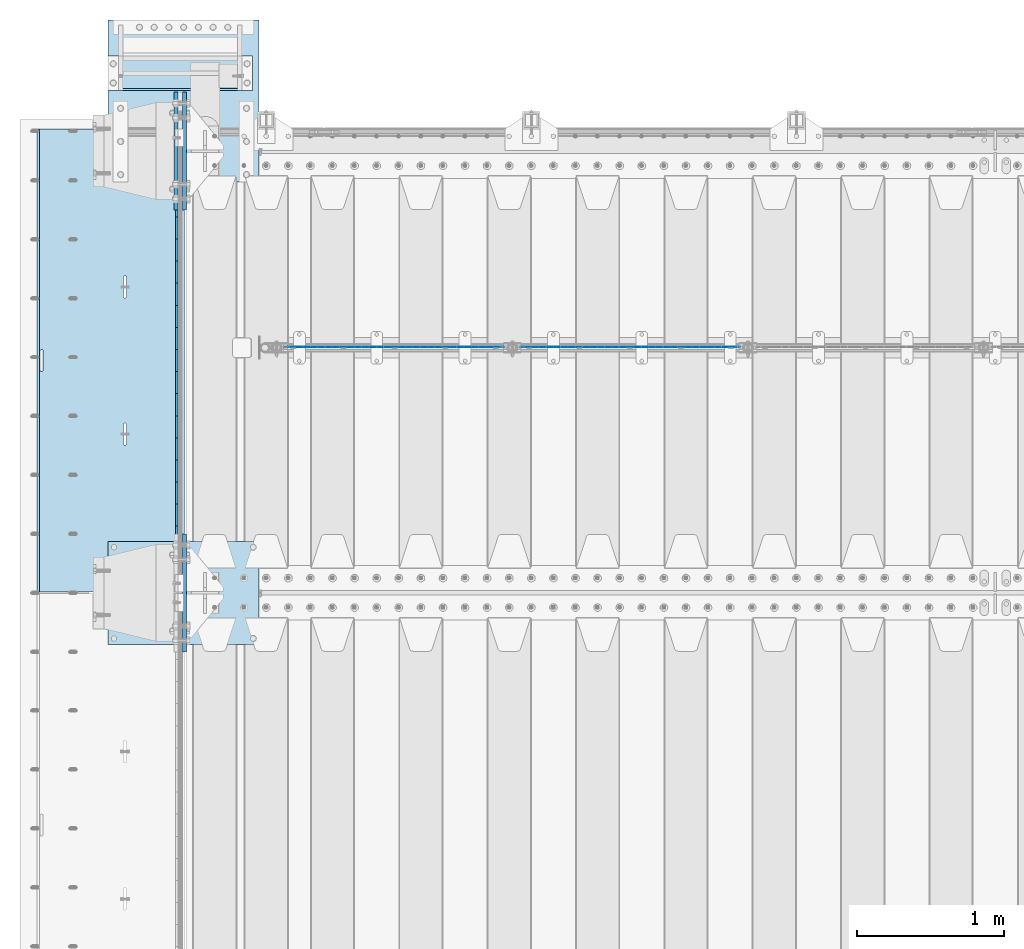
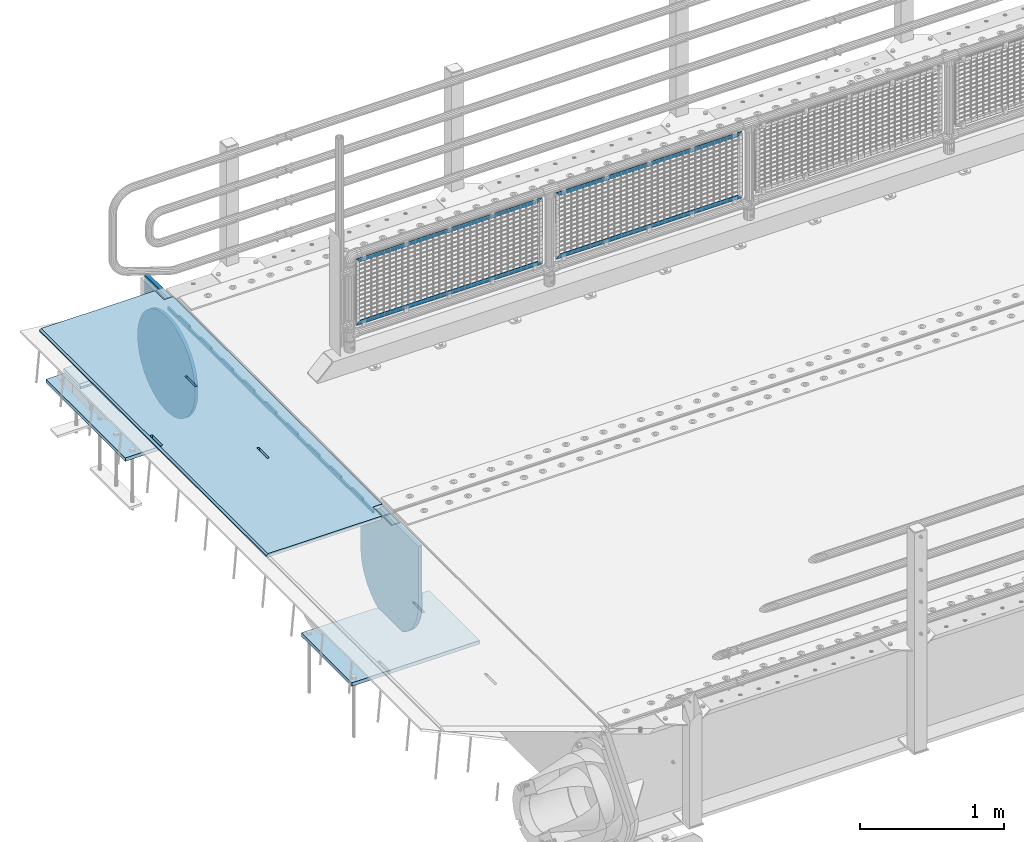
# One storey, part 163 of 208: 12 plates.
"""IFC2X3 building model written with IfcOpenShell, lengths in millimetres."""

import ifcopenshell
import ifcopenshell.guid

model = None  # the IFC model being written
_history = None  # IfcOwnerHistory: only IFC2X3 demands one
_inside = {}  # id of a spatial element -> (the spatial element, [elements in it])
_under = {}  # id of a project, library or spatial element -> (it, [spatial elements below it])
_declared = {}  # id of a project -> (the project, [libraries it declares])
_typed = {}  # id of a type object -> (the type object, [elements of that type])
_made_of = {}  # id of a material, layer set ... -> (it, [elements and type objects made of it])


def new_model(schema):
    """Start an empty IFC model of exactly this schema.

    Asked for "IFC4X3", IfcOpenShell would pick the latest addendum, in which some entities
    have other attributes; the version numbers below select the first issue.
    IFC2X3 requires an IfcOwnerHistory on every rooted entity: one is made here for all.
    """
    global model, _history
    if schema == "IFC4X3":
        model = ifcopenshell.file(schema_version=(4, 3, 0, 0))
    else:
        model = ifcopenshell.file(schema=schema)
    _inside.clear()
    _under.clear()
    _declared.clear()
    _typed.clear()
    _made_of.clear()
    _history = None
    if model.schema == "IFC2X3":
        org = make("IfcOrganization", Name="unknown")
        user = make(
            "IfcPersonAndOrganization",
            ThePerson=make("IfcPerson", FamilyName="unknown"),
            TheOrganization=org,
        )
        app = make(
            "IfcApplication",
            ApplicationDeveloper=org,
            Version="unknown",
            ApplicationFullName="unknown",
            ApplicationIdentifier="unknown",
        )
        _history = make(
            "IfcOwnerHistory",
            OwningUser=user,
            OwningApplication=app,
            ChangeAction="ADDED",
            CreationDate=0,
        )
    return model


def make(cls, **values):
    """One entity of the class cls with the attributes given. An attribute that is None is left unset."""
    return model.create_entity(
        cls, **{name: value for name, value in values.items() if value is not None}
    )


def rooted(cls, **values):
    """An entity with a GlobalId (a new one), such as an element, a storey or a relation."""
    return make(cls, GlobalId=ifcopenshell.guid.new(), OwnerHistory=_history, **values)


def si_unit(unit_type, name, prefix=None):
    """IfcSIUnit, for example si_unit("LENGTHUNIT", "METRE", prefix="MILLI")."""
    return make("IfcSIUnit", UnitType=unit_type, Prefix=prefix, Name=name)


def assignment(units):
    """IfcUnitAssignment: the units of a project."""
    return None if units is None else make("IfcUnitAssignment", Units=units)


def point(xyz):
    """IfcCartesianPoint."""
    return None if xyz is None else make("IfcCartesianPoint", Coordinates=xyz)


def direction(xyz):
    """IfcDirection."""
    return None if xyz is None else make("IfcDirection", DirectionRatios=xyz)


def frame(location, z_axis=None, x_axis=None):
    """IfcAxis2Placement3D, a coordinate frame: its origin and axes. An axis left out is left unset."""
    return make(
        "IfcAxis2Placement3D",
        Location=point(location),
        Axis=direction(z_axis),
        RefDirection=direction(x_axis),
    )


def origin_with_axes():
    """The frame at (0, 0, 0) with the z axis (0, 0, 1) and the x axis (1, 0, 0) written out."""
    return frame((0.0, 0.0, 0.0), z_axis=(0.0, 0.0, 1.0), x_axis=(1.0, 0.0, 0.0))


def place(relative_to, where):
    """IfcLocalPlacement: puts the frame where relative to a parent placement (None: the world)."""
    return make(
        "IfcLocalPlacement", PlacementRelTo=relative_to, RelativePlacement=where
    )


def context(
    kind, dimensions, precision=None, world=None, true_north=None, identifier=None
):
    """IfcGeometricRepresentationContext, for example the 3D "Model" context."""
    return make(
        "IfcGeometricRepresentationContext",
        ContextIdentifier=identifier,
        ContextType=kind,
        CoordinateSpaceDimension=dimensions,
        Precision=precision,
        WorldCoordinateSystem=world,
        TrueNorth=true_north,
    )


def subcontext(parent, identifier, kind, view, scale=None):
    """IfcGeometricRepresentationSubContext, for example "Body" below "Model"."""
    return make(
        "IfcGeometricRepresentationSubContext",
        ContextIdentifier=identifier,
        ContextType=kind,
        ParentContext=parent,
        TargetScale=scale,
        TargetView=view,
    )


def project(units=None, contexts=None):
    """IfcProject with its units and contexts."""
    return rooted(
        "IfcProject",
        Name="project",
        RepresentationContexts=contexts,
        UnitsInContext=assignment(units),
    )


def spatial(cls, under=None, at=None, **own):
    """A site, building, storey or space (cls), placed at a placement, below another one or the project."""
    s = rooted(cls, ObjectPlacement=at, **own)
    if under is not None:
        _under.setdefault(under.id(), (under, []))[1].append(s)
    return s


def faces_of(points, faces, orient=None, outer=None):
    """IfcFace entities. A face is a list of loops; a loop is a list of indices into points, from 0.

    orient and outer hold one flag for each loop. By default every Orientation is true, the
    first loop of a face is its IfcFaceOuterBound and the others are IfcFaceBound.
    """
    made = []
    for i, loops in enumerate(faces):
        bounds = []
        for j, loop in enumerate(loops):
            is_outer = j == 0 if outer is None else outer[i][j]
            bounds.append(
                make(
                    "IfcFaceOuterBound" if is_outer else "IfcFaceBound",
                    Bound=make("IfcPolyLoop", Polygon=[points[k] for k in loop]),
                    Orientation=True if orient is None else orient[i][j],
                )
            )
        made.append(make("IfcFace", Bounds=bounds))
    return made


def faceted_brep(points, faces, orient=None, outer=None, voids=None):
    """IfcFacetedBrep: a solid bounded by flat faces; with voids (closed shells), ...WithVoids."""
    shared = [point(p) for p in points]
    hull = make("IfcClosedShell", CfsFaces=faces_of(shared, faces, orient, outer))
    if voids is None:
        return make("IfcFacetedBrep", Outer=hull)
    return make(
        "IfcFacetedBrepWithVoids",
        Outer=hull,
        Voids=[
            make(cls, CfsFaces=faces_of(shared, fs, o, b)) for cls, fs, o, b in voids
        ],
    )


def shape(context_of_items, identifier, shape_type, items):
    """IfcShapeRepresentation: the items that make up one representation, for example the "Body"."""
    return make(
        "IfcShapeRepresentation",
        ContextOfItems=context_of_items,
        RepresentationIdentifier=identifier,
        RepresentationType=shape_type,
        Items=items,
    )


def material(Name=None, Category=None):
    """IfcMaterial."""
    return make("IfcMaterial", Name=Name, Category=Category)


def made_of(thing, what):
    """Note that an element or type object is made of a material, layer set ...; save() writes the relation."""
    if what is not None:
        _made_of.setdefault(what.id(), (what, []))[1].append(thing)
    return thing


def type_object(cls, material=None, **own):
    """A type object (cls), such as IfcWallType, which elements share."""
    return made_of(rooted(cls, **own), material)


def element(
    cls,
    number,
    at=None,
    inside=None,
    cuts=None,
    type_object=None,
    material=None,
    context=None,
    identifier="Body",
    shape_type=None,
    held_by="IfcProductDefinitionShape",
    body=None,
    shapes=None,
    **own,
):
    """One element of the class cls, such as IfcWall. Its Tag is "e" and its number.

    at: its placement. inside: the storey or other place that contains it. cuts: it is an
    opening in that element (IfcRelVoidsElement). A single representation is given by context,
    identifier, shape_type and body (its items); several are given by shapes. held_by: the class
    of the entity that holds the representations. save() writes the other relations.
    """
    e = rooted(cls, Tag="e%d" % number, ObjectPlacement=at, **own)
    if body is not None:
        shapes = [shape(context, identifier, shape_type, body)]
    if shapes is not None:
        e.Representation = make(held_by, Representations=shapes)
    if inside is not None:
        _inside.setdefault(inside.id(), (inside, []))[1].append(e)
    if cuts is not None:
        rooted(
            "IfcRelVoidsElement", RelatingBuildingElement=cuts, RelatedOpeningElement=e
        )
    if type_object is not None:
        _typed.setdefault(type_object.id(), (type_object, []))[1].append(e)
    return made_of(e, material)


def aggregate(whole, parts):
    """IfcRelAggregates: a whole, such as a stair, and the parts it consists of."""
    return rooted("IfcRelAggregates", RelatingObject=whole, RelatedObjects=parts)


def save(model, path):
    """Write the relations noted so far, then the file.

    IfcRelAggregates (storeys below a building ...), IfcRelContainedInSpatialStructure (elements
    in a storey), IfcRelDefinesByType, IfcRelAssociatesMaterial and IfcRelDeclares: one each for
    every whole, place, type object, material and project.
    """
    for whole, parts in _under.values():
        aggregate(whole, parts)
    for where, things in _inside.values():
        rooted(
            "IfcRelContainedInSpatialStructure",
            RelatedElements=things,
            RelatingStructure=where,
        )
    for kind, things in _typed.values():
        rooted("IfcRelDefinesByType", RelatedObjects=things, RelatingType=kind)
    for what, things in _made_of.values():
        rooted("IfcRelAssociatesMaterial", RelatedObjects=things, RelatingMaterial=what)
    for by, libraries in _declared.values():
        rooted("IfcRelDeclares", RelatingContext=by, RelatedDefinitions=libraries)
    model.write(path)


model = new_model("IFC2X3")

# Units and contexts
model_context = context("Model", 3, precision=1e-05, world=origin_with_axes())
body_context = subcontext(model_context, "Body", "Model", "MODEL_VIEW")
ifc_project = project(units=[si_unit("LENGTHUNIT", "METRE", prefix="MILLI"), si_unit("AREAUNIT", "SQUARE_METRE"), si_unit("VOLUMEUNIT", "CUBIC_METRE"), si_unit("MASSUNIT", "GRAM", prefix="KILO"), si_unit("TIMEUNIT", "SECOND"), si_unit("PLANEANGLEUNIT", "RADIAN"), si_unit("SOLIDANGLEUNIT", "STERADIAN"), si_unit("THERMODYNAMICTEMPERATUREUNIT", "DEGREE_CELSIUS"), si_unit("LUMINOUSINTENSITYUNIT", "LUMEN")], contexts=[model_context])

# Site, building, storey
site_placement = place(None, origin_with_axes())
site = spatial("IfcSite", under=ifc_project, at=site_placement, CompositionType="ELEMENT")
building_placement = place(site_placement, origin_with_axes())
building = spatial("IfcBuilding", under=site, at=building_placement, Name="Standard", CompositionType="ELEMENT")
storey_placement = place(building_placement, origin_with_axes())
storey = spatial("IfcBuildingStorey", under=building, at=storey_placement, Name="Undefined", CompositionType="ELEMENT", Elevation=0.0)

# Plates
ifc_material_1 = material(Name="STEEL/S355N")
plate_type_1 = type_object("IfcPlateType", PredefinedType="NOTDEFINED")
plate_1_placement = place(storey_placement, frame((-42455.0037545708, 6149.99992612935, -0.984391683580506), z_axis=(1.0000003385235e-09, -0.999999999987744, -4.95099999993936e-06), x_axis=(-0.999999999879068, -1.00000022173607e-09, -1.55519999981193e-05)))
element("IfcPlate", 1, at=plate_1_placement, inside=storey, type_object=plate_type_1, material=ifc_material_1, context=body_context, shape_type="Brep", body=[
    faceted_brep([(14.9998601691623, 15.0, 125.000024820844), (-0.000294611330900807, -0.000806902962786349, 124.999936248646), (-0.00191941577941179, 0.000806844426833264, 3020.00000492305), (14.9966216875036, 15.0, 3020.00007976653), (999.996459960938, 5.0, 1.81898940354586e-12), (984.996459960938, 15.0, 1.36424205265939e-12), (984.996459718779, 15.0, 3145.0), (999.996459718779, 5.0, 3145.0), (984.996459961352, -15.0, 1.81898940354586e-12), (999.996459960938, -4.99999999999848, 1.36424205265939e-12), (999.996459718779, -4.99999999999848, 3145.0), (984.996459719194, -15.0, 3145.0), (394.996621833969, -14.9999999992854, 1137.49999999815), (394.996621833976, 15.0, 1137.49999999815), (395.486056670787, 15.0, 1140.5901699419), (395.486056670779, -14.9999999992867, 1140.5901699419), (396.906451889772, 15.0, 1143.37785252108), (396.906451889765, -14.9999999992902, 1143.37785252108), (399.118769310422, 15.0, 1145.5901699419), (399.118769310422, -14.9999999992955, 1145.5901699419), (401.906451889488, 15.0, 1147.0105651611), (401.906451889496, -14.999999999302, 1147.0105651611), (404.996621833197, 15.0, 1147.49999999815), (404.996621833197, -14.9999999993092, 1147.49999999815), (408.086791776987, 15.0, 1147.0105651611), (408.086791776987, -14.9999999993163, 1147.0105651611), (410.874474356264, 15.0, 1145.5901699419), (410.874474356264, -14.9999999993227, 1145.5901699419), (413.08679177727, 15.0, 1143.37785252107), (413.08679177727, -14.9999999993277, 1143.37785252107), (414.507186996678, 15.0, 1140.59016994189), (414.507186996678, -14.9999999993308, 1140.59016994189), (414.996621833961, 15.0, 1137.49999999814), (414.996621833961, -14.9999999993318, 1137.49999999814), (414.996621843871, 15.0, 1007.49999999814), (414.996621843871, -14.9999999993243, 1007.49999999814), (414.507187007061, 15.0, 1004.40983005439), (414.507187007061, -14.999999999323, 1004.4098300544), (413.086791788068, 15.0, 1001.62214747522), (413.086791788068, -14.9999999993196, 1001.62214747522), (410.874474367403, 15.0, 999.409830054399), (410.874474367411, -14.9999999993143, 999.409830054399), (408.086791788344, 15.0, 997.989434835199), (408.086791788344, -14.9999999993078, 997.989434835199), (404.996621844744, 15.0, 997.499999998151), (404.996621844752, -14.9999999993006, 997.499999998151), (401.906451900963, 15.0, 997.989434835199), (401.906451900963, -14.9999999992934, 997.989434835199), (399.118769321678, 15.0, 999.409830054401), (399.118769321678, -14.999999999287, 999.409830054401), (396.906451900686, 15.0, 1001.62214747523), (396.906451900679, -14.999999999282, 1001.62214747523), (395.486056681264, 15.0, 1004.4098300544), (395.486056681264, -14.9999999992789, 1004.4098300544), (394.99662184398, 15.0, 1007.49999999815), (394.996621843988, -14.999999999278, 1007.49999999815), (960.486056642767, -15.0000000006174, 1504.40983005415), (960.486056642767, 15.0, 1504.40983005415), (959.996621805483, 15.0, 1507.4999999979), (959.996621805491, -15.0000000006165, 1507.4999999979), (961.906451862189, -15.0000000006206, 1501.62214747498), (961.906451862189, 15.0, 1501.62214747498), (964.118769283188, -15.0000000006256, 1499.40983005415), (964.118769283188, 15.0, 1499.40983005415), (966.90645186248, -15.0000000006319, 1497.98943483495), (966.90645186248, 15.0, 1497.98943483495), (969.996621806255, -15.0000000006391, 1497.4999999979), (969.996621806247, 15.0, 1497.4999999979), (973.086791749854, -15.0000000006463, 1497.98943483495), (973.086791749854, 15.0, 1497.98943483495), (975.874474328928, -15.0000000006528, 1499.40983005415), (975.874474328921, 15.0, 1499.40983005415), (978.086791749571, -15.0000000006581, 1501.62214747497), (978.086791749571, 15.0, 1501.62214747497), (979.507186968556, -15.0000000006615, 1504.40983005415), (979.507186968556, 15.0, 1504.40983005415), (979.996621805367, -15.0000000006628, 1507.49999999789), (979.996621805367, 15.0, 1507.49999999789), (979.996621795464, -15.0000000006703, 1637.49999999789), (979.996621795464, 15.0, 1637.49999999789), (979.507186958181, -15.0000000006694, 1640.59016994164), (979.507186958181, 15.0, 1640.59016994164), (978.086791738773, -15.0000000006662, 1643.37785252082), (978.086791738773, 15.0, 1643.37785252082), (975.874474317781, -15.0000000006612, 1645.59016994165), (975.874474317781, 15.0, 1645.59016994165), (973.086791738489, -15.0000000006548, 1647.01056516085), (973.086791738489, 15.0, 1647.01056516085), (969.996621794693, -15.0000000006477, 1647.4999999979), (969.9966217947, 15.0, 1647.4999999979), (966.906451851006, -15.0000000006405, 1647.01056516085), (966.906451850999, 15.0, 1647.01056516085), (964.118769271932, -15.000000000634, 1645.59016994165), (964.118769271932, 15.0, 1645.59016994165), (961.906451851275, -15.0000000006287, 1643.37785252083), (961.906451851275, 15.0, 1643.37785252083), (960.486056632282, -15.0000000006253, 1640.59016994165), (960.486056632282, 15.0, 1640.59016994165), (959.996621795472, -15.000000000624, 1637.4999999979), (959.996621795472, 15.0, 1637.4999999979), (-0.000449375191237777, -14.9999999951863, 124.999861417758), (-0.00046036208368605, -15.00000004538, 3019.99993008592), (74.9964039658807, -14.999999998652, 3019.99993015413), (74.9968705258798, 15.0, 3020.00007982413), (74.9962640909944, -15.0, 3145.0), (74.9967306509934, 15.0, 3145.0), (74.9997820615899, -15.0, 0.0), (75.0002485915829, 15.0, -4.54747350886464e-13), (74.999642186689, -15.0, 124.999930084114), (75.0001087166966, 15.0, 125.000079754114), (395.486056593785, -15.0000000032097, 2140.59016994142), (396.906451812763, -15.0000000031847, 2143.3778525206), (399.118769233428, -15.0000000031445, 2145.59016994142), (401.906451812487, -15.0000000030931, 2147.01056516062), (404.996621756189, -15.0000000030354, 2147.49999999767), (408.086791699985, -15.0000000029771, 2147.01056516062), (410.874474279262, -15.000000002924, 2145.59016994142), (413.086791700269, -15.0000000028812, 2143.37785252059), (414.507186919684, -15.000000002853, 2140.59016994141), (414.996621756967, -15.000000002842, 2137.49999999766), (414.996621766863, -15.0000000027658, 2007.49999999766), (414.507186930052, -15.0000000027732, 2004.40983005391), (413.086791711066, -15.0000000027982, 2001.62214747474), (410.874474290409, -15.0000000028384, 1999.40983005392), (408.08679171135, -15.0000000028898, 1997.98943483472), (404.996621767757, -15.0000000029475, 1997.49999999767), (401.906451823961, -15.0000000030058, 1997.98943483472), (399.118769244684, -15.0000000030589, 1999.40983005392), (396.906451823685, -15.0000000031017, 2001.62214747475), (395.486056604263, -15.0000000031299, 2004.40983005392), (394.996621766979, -15.0000000031409, 2007.49999999767), (394.996621756974, -15.0000000032171, 2137.49999999767), (396.906451823692, 15.0, 2001.62214747475), (395.486056604263, 15.0, 2004.40983005392), (399.118769244684, 15.0, 1999.40983005392), (401.906451823961, 15.0, 1997.98943483472), (404.99662176775, 15.0, 1997.49999999767), (408.08679171135, 15.0, 1997.98943483472), (410.874474290409, 15.0, 1999.40983005392), (413.086791711074, 15.0, 2001.62214747474), (414.507186930052, 15.0, 2004.40983005391), (414.996621766863, 15.0, 2007.49999999766), (414.996621756967, 15.0, 2137.49999999766), (414.507186919676, 15.0, 2140.59016994141), (413.086791700269, 15.0, 2143.37785252059), (410.87447427927, 15.0, 2145.59016994142), (408.086791699985, 15.0, 2147.01056516062), (404.996621756189, 15.0, 2147.49999999767), (401.90645181248, 15.0, 2147.01056516062), (399.118769233428, 15.0, 2145.59016994142), (396.906451812771, 15.0, 2143.3778525206), (395.486056593785, 15.0, 2140.59016994142), (394.996621756974, 15.0, 2137.49999999767), (394.996621766972, 15.0, 2007.49999999767)], [[[0, 1, 2, 3]], [[4, 5, 6, 7]], [[8, 9, 10, 11]], [[12, 13, 14, 15]], [[15, 14, 16, 17]], [[17, 16, 18, 19]], [[19, 18, 20, 21]], [[21, 20, 22, 23]], [[23, 22, 24, 25]], [[25, 24, 26, 27]], [[27, 26, 28, 29]], [[29, 28, 30, 31]], [[31, 30, 32, 33]], [[33, 32, 34, 35]], [[35, 34, 36, 37]], [[37, 36, 38, 39]], [[39, 38, 40, 41]], [[41, 40, 42, 43]], [[43, 42, 44, 45]], [[45, 44, 46, 47]], [[47, 46, 48, 49]], [[49, 48, 50, 51]], [[51, 50, 52, 53]], [[53, 52, 54, 55]], [[55, 54, 13, 12]], [[56, 57, 58, 59]], [[60, 61, 57, 56]], [[62, 63, 61, 60]], [[64, 65, 63, 62]], [[66, 67, 65, 64]], [[68, 69, 67, 66]], [[70, 71, 69, 68]], [[72, 73, 71, 70]], [[74, 75, 73, 72]], [[76, 77, 75, 74]], [[78, 79, 77, 76]], [[80, 81, 79, 78]], [[82, 83, 81, 80]], [[84, 85, 83, 82]], [[86, 87, 85, 84]], [[88, 89, 87, 86]], [[90, 91, 89, 88]], [[92, 93, 91, 90]], [[94, 95, 93, 92]], [[96, 97, 95, 94]], [[98, 99, 97, 96]], [[59, 58, 99, 98]], [[100, 101, 2, 1]], [[101, 102, 103, 3, 2]], [[104, 105, 103, 102]], [[7, 6, 105, 104, 11, 10]], [[4, 7, 10, 9]], [[106, 107, 5, 4, 9, 8]], [[106, 108, 109, 107]], [[109, 108, 100, 1, 0]], [[104, 102, 101, 100, 108, 106, 8, 11], [15, 17, 19, 21, 23, 25, 27, 29, 31, 33, 35, 37, 39, 41, 43, 45, 47, 49, 51, 53, 55, 12], [96, 94, 92, 90, 88, 86, 84, 82, 80, 78, 76, 74, 72, 70, 68, 66, 64, 62, 60, 56, 59, 98], [110, 111, 112, 113, 114, 115, 116, 117, 118, 119, 120, 121, 122, 123, 124, 125, 126, 127, 128, 129, 130, 131]], [[128, 132, 133, 129]], [[127, 134, 132, 128]], [[126, 135, 134, 127]], [[125, 136, 135, 126]], [[124, 137, 136, 125]], [[123, 138, 137, 124]], [[122, 139, 138, 123]], [[121, 140, 139, 122]], [[120, 141, 140, 121]], [[119, 142, 141, 120]], [[118, 143, 142, 119]], [[117, 144, 143, 118]], [[116, 145, 144, 117]], [[115, 146, 145, 116]], [[114, 147, 146, 115]], [[113, 148, 147, 114]], [[112, 149, 148, 113]], [[111, 150, 149, 112]], [[110, 151, 150, 111]], [[131, 152, 151, 110]], [[130, 153, 152, 131]], [[129, 133, 153, 130]], [[107, 109, 0, 3, 103, 105, 6, 5], [50, 48, 46, 44, 42, 40, 38, 36, 34, 32, 30, 28, 26, 24, 22, 20, 18, 16, 14, 13, 54, 52], [132, 134, 135, 136, 137, 138, 139, 140, 141, 142, 143, 144, 145, 146, 147, 148, 149, 150, 151, 152, 153, 133], [61, 63, 65, 67, 69, 71, 73, 75, 77, 79, 81, 83, 85, 87, 89, 91, 93, 95, 97, 99, 58, 57]]]),
])
plate_type_2 = type_object("IfcPlateType", PredefinedType="NOTDEFINED")
plate_2_placement = place(storey_placement, frame((-42507.5, 6002.50009937252, -35.9858217417067), z_axis=(1.0000003385235e-09, -0.999999999987744, -4.95099999993936e-06), x_axis=(0.0, 4.95099999111973e-06, -0.999999999987744)))
element("IfcPlate", 2, at=plate_2_placement, inside=storey, type_object=plate_type_2, material=ifc_material_1, context=body_context, shape_type="Brep", body=[
    faceted_brep([(0.0, -7.5, -4.54747350886464e-13), (5.96145355302724e-12, -7.5, 150.0), (5.96145355302724e-12, 7.5, 150.0), (0.0, 7.5, -4.54747350886464e-13), (-15.0000000000013, -7.5, 150.0), (-15.0000000000013, 7.5, 150.0), (-15.0000000000026, -7.5, 300.0), (-15.0000000000026, 7.5, 300.0), (1.00826014204358e-11, -7.5, 300.0), (1.00826014204358e-11, 7.5, 300.0), (1.05870867628255e-11, -7.5, 450.0), (1.05870867628255e-11, 7.5, 450.0), (-15.000000000004, -7.5, 450.0), (-15.000000000004, 7.5, 450.0), (-15.0000000000053, -7.5, 600.0), (-15.0000000000053, 7.5, 600.0), (1.65343294611375e-11, -7.5, 600.0), (1.65343294611375e-11, 7.5, 600.0), (1.88506987797155e-11, -7.5, 750.0), (1.88506987797155e-11, 7.5, 750.0), (-15.0000000000066, -7.5, 750.0), (-15.0000000000066, 7.5, 750.0), (-15.0000000000079, -7.5, 900.0), (-15.0000000000079, 7.5, 900.0), (2.48050469053851e-11, -7.5, 900.0), (2.48050469053851e-11, 7.5, 900.0), (2.7121416223963e-11, -7.5, 1050.0), (2.7121416223963e-11, 7.5, 1050.0), (-15.0000000000093, -7.5, 1050.0), (-15.0000000000093, 7.5, 1050.0), (-15.0000000000106, -7.5, 1200.0), (-15.0000000000106, 7.5, 1200.0), (3.12638803734444e-11, -7.5, 1200.0), (3.12638803734444e-11, 7.5, 1200.0), (3.53921336682106e-11, -7.5, 1350.0), (3.53921336682106e-11, 7.5, 1350.0), (-15.0000000000119, -7.5, 1350.0), (-15.0000000000119, 7.5, 1350.0), (-15.0000000000132, -7.5, 1500.0), (-15.0000000000132, 7.5, 1500.0), (3.77085029867885e-11, -7.5, 1500.0), (3.77085029867885e-11, 7.5, 1500.0), (4.36628511124582e-11, -7.5, 1650.0), (4.36628511124582e-11, 7.5, 1650.0), (-15.0000000000145, -7.5, 1650.0), (-15.0000000000145, 7.5, 1650.0), (-15.0000000000159, -7.5, 1800.0), (-15.0000000000159, 7.5, 1800.0), (4.41531256001326e-11, -7.5, 1800.0), (4.41531256001326e-11, 7.5, 1800.0), (4.82884843222564e-11, -7.5, 1950.0), (4.82884843222564e-11, 7.5, 1950.0), (-15.0000000000172, -7.5, 1950.0), (-15.0000000000172, 7.5, 1950.0), (-15.0000000000185, -7.5, 2100.0), (-15.0000000000185, 7.5, 2100.0), (5.24309484717378e-11, -7.5, 2100.0), (5.24309484717378e-11, 7.5, 2100.0), (5.47402123629581e-11, -7.5, 2250.0), (5.47402123629581e-11, 7.5, 2250.0), (-15.0000000000198, -7.5, 2250.0), (-15.0000000000198, 7.5, 2250.0), (-15.0000000000212, -7.5, 2400.0), (-15.0000000000212, 7.5, 2400.0), (6.06945604886278e-11, -7.5, 2400.0), (6.06945604886278e-11, 7.5, 2400.0), (6.30038243798481e-11, -7.5, 2550.0), (6.30038243798481e-11, 7.5, 2550.0), (-15.0000000000225, -7.5, 2550.0), (-15.0000000000225, 7.5, 2550.0), (-15.0000000000238, -7.5, 2700.0), (-15.0000000000238, 7.5, 2700.0), (6.53272991257836e-11, -7.5, 2700.0), (6.53272991257836e-11, 7.5, 2700.0), (7.12745418240957e-11, -7.5, 2850.0), (7.12745418240957e-11, 7.5, 2850.0), (24.9999999999749, -7.5, 2850.0), (24.9999999999749, 7.5, 2850.0), (25.0, -7.5, -2.27373675443232e-12), (25.0, 7.5, -2.27373675443232e-12)], [[[0, 1, 2, 3]], [[1, 4, 5, 2]], [[4, 6, 7, 5]], [[6, 8, 9, 7]], [[8, 10, 11, 9]], [[10, 12, 13, 11]], [[12, 14, 15, 13]], [[14, 16, 17, 15]], [[16, 18, 19, 17]], [[18, 20, 21, 19]], [[20, 22, 23, 21]], [[22, 24, 25, 23]], [[24, 26, 27, 25]], [[26, 28, 29, 27]], [[28, 30, 31, 29]], [[30, 32, 33, 31]], [[32, 34, 35, 33]], [[34, 36, 37, 35]], [[36, 38, 39, 37]], [[38, 40, 41, 39]], [[40, 42, 43, 41]], [[42, 44, 45, 43]], [[44, 46, 47, 45]], [[46, 48, 49, 47]], [[48, 50, 51, 49]], [[50, 52, 53, 51]], [[52, 54, 55, 53]], [[54, 56, 57, 55]], [[56, 58, 59, 57]], [[58, 60, 61, 59]], [[60, 62, 63, 61]], [[62, 64, 65, 63]], [[64, 66, 67, 65]], [[66, 68, 69, 67]], [[68, 70, 71, 69]], [[70, 72, 73, 71]], [[72, 74, 75, 73]], [[74, 76, 77, 75]], [[76, 78, 79, 77]], [[78, 0, 3, 79]], [[5, 7, 9, 11, 13, 15, 17, 19, 21, 23, 25, 27, 29, 31, 33, 35, 37, 39, 41, 43, 45, 47, 49, 51, 53, 55, 57, 59, 61, 63, 65, 67, 69, 71, 73, 75, 77, 79, 3, 2]], [[78, 76, 74, 72, 70, 68, 66, 64, 62, 60, 58, 56, 54, 52, 50, 48, 46, 44, 42, 40, 38, 36, 34, 32, 30, 28, 26, 24, 22, 20, 18, 16, 14, 12, 10, 8, 6, 4, 1, 0]]]),
])
ifc_material_2 = material(Name="Misc_Undefined")
plate_type_3 = type_object("IfcPlateType", PredefinedType="NOTDEFINED")
plate_3_placement = place(storey_placement, frame((-40175.4949882696, 4670.5, 351.520303374641), z_axis=(0.0, 0.0, 1.0), x_axis=(1.0, 0.0, 0.0)))
element("IfcPlate", 3, at=plate_3_placement, inside=storey, type_object=plate_type_3, material=ifc_material_2, context=body_context, shape_type="Brep", body=[
    faceted_brep([(0.0, -1.49999999999909, 3.63797880709171e-12), (35.0002975463867, -1.5, 34.9996948242187), (35.0002975463867, 1.5, 34.9996948242187), (0.0, 1.50000000000182, 3.63797880709171e-12), (1457.99035644531, -1.5, 34.9999923706055), (1457.99035644531, 1.5, 34.9999923706055), (1492.98999023437, -1.5, -2.87985812974512e-09), (1492.98999023437, 1.5, -2.87985812974512e-09)], [[[0, 1, 2, 3]], [[1, 4, 5, 2]], [[4, 6, 7, 5]], [[6, 0, 3, 7]], [[5, 7, 3, 2]], [[6, 4, 1, 0]]]),
])
plate_4_placement = place(storey_placement, frame((-38682.4999998124, 4670.5, 914.520000175701), z_axis=(-0.707103624179499, 0.0, 0.707109938179501), x_axis=(-0.707109938179511, 0.0, -0.707103624179489)))
element("IfcPlate", 4, at=plate_4_placement, inside=storey, type_object=plate_type_3, material=ifc_material_2, context=body_context, shape_type="Brep", body=[
    faceted_brep([(0.0, -1.49999999999909, 3.63797880709171e-12), (1055.71520996092, -1.5, 1055.70581054688), (1055.71520996092, 1.5, 1055.70581054688), (0.0, 1.50000000000182, 3.63797880709171e-12), (1055.7081298828, -1.5, 1006.20135498047), (1055.7081298828, 1.5, 1006.20135498047), (49.4976959228516, -1.5, 6.91215973347425e-11), (49.4976959228516, 1.5, 6.91215973347425e-11)], [[[0, 1, 2, 3]], [[1, 4, 5, 2]], [[4, 6, 7, 5]], [[6, 0, 3, 7]], [[5, 7, 3, 2]], [[6, 4, 1, 0]]]),
])
plate_5_placement = place(storey_placement, frame((-41775.4949882696, 4670.5, 351.520303374641), z_axis=(0.0, 0.0, 1.0), x_axis=(1.0, 0.0, 0.0)))
element("IfcPlate", 5, at=plate_5_placement, inside=storey, type_object=plate_type_3, material=ifc_material_2, context=body_context, shape_type="Brep", body=[
    faceted_brep([(0.0, -1.49999999999909, 3.63797880709171e-12), (35.0002975463867, -1.5, 34.9996948242187), (35.0002975463867, 1.5, 34.9996948242187), (0.0, 1.50000000000182, 3.63797880709171e-12), (1457.99035644531, -1.5, 34.9999923706055), (1457.99035644531, 1.5, 34.9999923706055), (1492.98999023437, -1.5, -2.87985812974512e-09), (1492.98999023437, 1.5, -2.87985812974512e-09)], [[[0, 1, 2, 3]], [[1, 4, 5, 2]], [[4, 6, 7, 5]], [[6, 0, 3, 7]], [[5, 7, 3, 2]], [[6, 4, 1, 0]]]),
])
plate_6_placement = place(storey_placement, frame((-40282.4999998124, 4670.5, 914.520000175701), z_axis=(-0.707103624179499, 0.0, 0.707109938179501), x_axis=(-0.707109938179511, 0.0, -0.707103624179489)))
element("IfcPlate", 6, at=plate_6_placement, inside=storey, type_object=plate_type_3, material=ifc_material_2, context=body_context, shape_type="Brep", body=[
    faceted_brep([(0.0, -1.49999999999909, 3.63797880709171e-12), (1055.71520996092, -1.5, 1055.70581054688), (1055.71520996092, 1.5, 1055.70581054688), (0.0, 1.50000000000182, 3.63797880709171e-12), (1055.7081298828, -1.5, 1006.20135498047), (1055.7081298828, 1.5, 1006.20135498047), (49.4976959228516, -1.5, 6.91215973347425e-11), (49.4976959228516, 1.5, 6.91215973347425e-11)], [[[0, 1, 2, 3]], [[1, 4, 5, 2]], [[4, 6, 7, 5]], [[6, 0, 3, 7]], [[5, 7, 3, 2]], [[6, 4, 1, 0]]]),
])
plate_type_4 = type_object("IfcPlateType", PredefinedType="NOTDEFINED")
plate_7_placement = place(storey_placement, frame((-42455.0, 5600.0, -20.0), z_axis=(0.0, 1.0, 0.0), x_axis=(0.0, 0.0, -1.0)))
element("IfcPlate", 7, at=plate_7_placement, inside=storey, type_object=plate_type_4, material=ifc_material_1, context=body_context, shape_type="Brep", body=[
    faceted_brep([(855.0, -15.0, 572.963114671446), (855.0, 15.0, 572.963114671446), (849.182410261259, 15.0, 585.889268817516), (849.182410261259, -15.0, 585.889268817516), (824.193546357442, 15.0, 627.225898692465), (824.193546357442, -15.0, 627.225898692465), (794.404299268426, 15.0, 665.249063296316), (794.404299268426, -15.0, 665.249063296316), (760.249063296309, 15.0, 699.404299268435), (760.249063296309, -15.0, 699.404299268435), (722.22589869246, 15.0, 729.193546357455), (722.22589869246, -15.0, 729.193546357455), (680.889268817512, 15.0, 754.182410261274), (680.889268817512, -15.0, 754.182410261274), (636.841954817025, 15.0, 774.006497074155), (636.841954817025, -15.0, 774.006497074155), (590.726265715041, 15.0, 788.37672697041), (590.726265715041, -15.0, 788.37672697041), (543.214672102153, 15.0, 797.083549639213), (543.214672102153, -15.0, 797.083549639213), (495.0, -15.0, 800.000000000029), (495.0, 15.0, 800.0), (494.999999999412, -15.0, 0.0), (494.999999999412, 15.0, 0.0), (543.214672102129, 15.0, 2.91645036080718), (543.214672102129, -15.0, 2.91645036080718), (590.726265715023, 15.0, 11.6232730296078), (590.726265715023, -15.0, 11.6232730296078), (636.841954817014, 15.0, 25.9935029258631), (636.841954817014, -15.0, 25.9935029258631), (680.889268817507, 15.0, 45.8175897387455), (680.889268817507, -15.0, 45.8175897387455), (722.225898692462, 15.0, 70.8064536425663), (722.225898692462, -15.0, 70.8064536425663), (760.249063296318, 15.0, 100.595700731588), (760.249063296318, -15.0, 100.595700731588), (794.404299268441, 15.0, 134.750936703711), (794.404299268441, -15.0, 134.750936703711), (824.193546357463, 15.0, 172.774101307567), (824.193546357463, -15.0, 172.774101307567), (849.182410261284, 15.0, 214.110731182522), (849.182410261284, -15.0, 214.110731182522), (855.0, -15.0, 227.036885328535), (855.0, 15.0, 227.036885328535), (0.0, -15.0, 0.0), (0.0, 15.0, 0.0), (0.0, 15.0, 800.0), (0.0, -15.0, 800.0)], [[[0, 1, 2, 3]], [[3, 2, 4, 5]], [[5, 4, 6, 7]], [[7, 6, 8, 9]], [[9, 8, 10, 11]], [[11, 10, 12, 13]], [[13, 12, 14, 15]], [[15, 14, 16, 17]], [[17, 16, 18, 19]], [[20, 19, 18, 21]], [[22, 23, 24, 25]], [[25, 24, 26, 27]], [[27, 26, 28, 29]], [[29, 28, 30, 31]], [[31, 30, 32, 33]], [[33, 32, 34, 35]], [[35, 34, 36, 37]], [[37, 36, 38, 39]], [[39, 38, 40, 41]], [[42, 41, 40, 43]], [[42, 43, 1, 0]], [[44, 45, 23, 22]], [[16, 14, 12, 10, 8, 6, 4, 2, 1, 43, 40, 38, 36, 34, 32, 30, 28, 26, 24, 23, 45, 46, 21, 18]], [[44, 47, 46, 45]], [[46, 47, 20, 21]], [[47, 44, 22, 25, 27, 29, 31, 33, 35, 37, 39, 41, 42, 0, 3, 5, 7, 9, 11, 13, 15, 17, 19, 20]]]),
])
plate_8_placement = place(storey_placement, frame((-42455.0, 2600.0, -20.0), z_axis=(0.0, 1.0, 0.0), x_axis=(0.0, 0.0, -1.0)))
element("IfcPlate", 8, at=plate_8_placement, inside=storey, type_object=plate_type_4, material=ifc_material_1, context=body_context, shape_type="Brep", body=[
    faceted_brep([(855.0, -15.0, 572.963114671446), (855.0, 15.0, 572.963114671446), (849.182410261259, 15.0, 585.889268817516), (849.182410261259, -15.0, 585.889268817516), (824.193546357442, 15.0, 627.225898692465), (824.193546357442, -15.0, 627.225898692465), (794.404299268426, 15.0, 665.249063296316), (794.404299268426, -15.0, 665.249063296316), (760.249063296309, 15.0, 699.404299268435), (760.249063296309, -15.0, 699.404299268435), (722.22589869246, 15.0, 729.193546357455), (722.22589869246, -15.0, 729.193546357455), (680.889268817512, 15.0, 754.182410261274), (680.889268817512, -15.0, 754.182410261274), (636.841954817025, 15.0, 774.006497074155), (636.841954817025, -15.0, 774.006497074155), (590.726265715041, 15.0, 788.37672697041), (590.726265715041, -15.0, 788.37672697041), (543.214672102153, 15.0, 797.083549639213), (543.214672102153, -15.0, 797.083549639213), (495.0, -15.0, 800.000000000029), (495.0, 15.0, 800.0), (494.999999999412, -15.0, 0.0), (494.999999999412, 15.0, 0.0), (543.214672102129, 15.0, 2.91645036080718), (543.214672102129, -15.0, 2.91645036080718), (590.726265715023, 15.0, 11.6232730296078), (590.726265715023, -15.0, 11.6232730296078), (636.841954817014, 15.0, 25.9935029258631), (636.841954817014, -15.0, 25.9935029258631), (680.889268817507, 15.0, 45.8175897387455), (680.889268817507, -15.0, 45.8175897387455), (722.225898692462, 15.0, 70.8064536425663), (722.225898692462, -15.0, 70.8064536425663), (760.249063296318, 15.0, 100.595700731588), (760.249063296318, -15.0, 100.595700731588), (794.404299268441, 15.0, 134.750936703711), (794.404299268441, -15.0, 134.750936703711), (824.193546357463, 15.0, 172.774101307567), (824.193546357463, -15.0, 172.774101307567), (849.182410261284, 15.0, 214.110731182522), (849.182410261284, -15.0, 214.110731182522), (855.0, -15.0, 227.036885328535), (855.0, 15.0, 227.036885328535), (0.0, -15.0, 0.0), (0.0, 15.0, 0.0), (0.0, 15.0, 800.0), (0.0, -15.0, 800.0)], [[[0, 1, 2, 3]], [[3, 2, 4, 5]], [[5, 4, 6, 7]], [[7, 6, 8, 9]], [[9, 8, 10, 11]], [[11, 10, 12, 13]], [[13, 12, 14, 15]], [[15, 14, 16, 17]], [[17, 16, 18, 19]], [[20, 19, 18, 21]], [[22, 23, 24, 25]], [[25, 24, 26, 27]], [[27, 26, 28, 29]], [[29, 28, 30, 31]], [[31, 30, 32, 33]], [[33, 32, 34, 35]], [[35, 34, 36, 37]], [[37, 36, 38, 39]], [[39, 38, 40, 41]], [[42, 41, 40, 43]], [[42, 43, 1, 0]], [[44, 45, 23, 22]], [[16, 14, 12, 10, 8, 6, 4, 2, 1, 43, 40, 38, 36, 34, 32, 30, 28, 26, 24, 23, 45, 46, 21, 18]], [[44, 47, 46, 45]], [[46, 47, 20, 21]], [[47, 44, 22, 25, 27, 29, 31, 33, 35, 37, 39, 41, 42, 0, 3, 5, 7, 9, 11, 13, 15, 17, 19, 20]]]),
])
plate_type_5 = type_object("IfcPlateType", PredefinedType="NOTDEFINED")
plate_9_placement = place(storey_placement, frame((-42512.5, 6400.0, -114.999999999998), z_axis=(0.0, 0.0, -1.0), x_axis=(0.0, -1.0, 0.0)))
element("IfcPlate", 9, at=plate_9_placement, inside=storey, type_object=plate_type_5, material=ifc_material_1, context=body_context, shape_type="Brep", body=[
    faceted_brep([(0.0, -12.5, 400.0), (2.91645036078444, -12.5, 448.214672102168), (2.91645036078444, 12.5, 448.214672102168), (0.0, 12.5, 400.0), (11.6232730295887, -12.5, 495.726265715062), (11.6232730295887, 12.5, 495.726265715062), (25.9935029258468, -12.5, 541.841954817051), (25.9935029258468, 12.5, 541.841954817051), (45.81758973873, -12.5, 585.889268817542), (45.81758973873, 12.5, 585.889268817542), (70.8064536425536, -12.5, 627.225898692492), (70.8064536425536, 12.5, 627.225898692492), (100.595700731576, -12.5, 665.249063296343), (100.595700731576, 12.5, 665.249063296343), (134.750936703701, -12.5, 699.404299268459), (134.750936703701, 12.5, 699.404299268459), (172.774101307557, -12.5, 729.193546357476), (172.774101307557, 12.5, 729.193546357476), (214.110731182515, -12.5, 754.182410261292), (214.110731182515, 12.5, 754.182410261292), (258.158045183012, -12.5, 774.006497074168), (258.158045183012, 12.5, 774.006497074168), (304.273734285007, -12.5, 788.376726970419), (304.273734285007, 12.5, 788.376726970419), (351.785327897906, -12.5, 797.083549639215), (351.785327897906, 12.5, 797.083549639215), (400.0, -12.5, 800.0), (400.0, 12.5, 800.0), (448.214672102084, -12.5, 797.083549639379), (448.214672102084, 12.5, 797.083549639379), (495.726265714995, -12.5, 788.37672697056), (495.726265714995, 12.5, 788.37672697056), (541.841954817006, -12.5, 774.006497074283), (541.841954817006, 12.5, 774.006497074283), (585.889268817518, -12.5, 754.182410261379), (585.889268817518, 12.5, 754.182410261379), (627.225898692492, -12.5, 729.193546357534), (627.225898692492, 12.5, 729.193546357534), (665.249063296365, -12.5, 699.404299268488), (665.249063296365, 12.5, 699.404299268488), (699.404299268504, -12.5, 665.249063296339), (699.404299268504, 12.5, 665.249063296339), (729.193546357543, -12.5, 627.225898692458), (729.193546357543, 12.5, 627.225898692458), (754.182410261379, -12.5, 585.889268817477), (754.182410261379, 12.5, 585.889268817477), (774.006497074275, -12.5, 541.841954816959), (774.006497074275, 12.5, 541.841954816959), (788.376726970542, -12.5, 495.726265714942), (788.376726970542, 12.5, 495.726265714942), (797.083549639352, -12.5, 448.214672102024), (797.083549639352, 12.5, 448.214672102024), (800.0, -12.5, 400.0), (800.0, 12.5, 400.0), (797.083549639225, -12.5, 351.785327897849), (797.083549639225, 12.5, 351.785327897849), (788.376726970419, -12.5, 304.273734284957), (788.376726970419, 12.5, 304.273734284957), (774.006497074162, -12.5, 258.158045182969), (774.006497074162, 12.5, 258.158045182969), (754.182410261277, -12.5, 214.110731182482), (754.182410261277, 12.5, 214.110731182482), (729.193546357454, -12.5, 172.774101307534), (729.193546357454, 12.5, 172.774101307534), (699.40429926843, -12.5, 134.750936703684), (699.40429926843, 12.5, 134.750936703684), (665.249063296305, -12.5, 100.595700731569), (665.249063296305, 12.5, 100.595700731569), (627.225898692448, -12.5, 70.8064536425563), (627.225898692448, 12.5, 70.8064536425563), (585.889268817491, -12.5, 45.8175897387418), (585.889268817491, 12.5, 45.8175897387418), (541.841954816997, -12.5, 25.9935029258686), (541.841954816997, 12.5, 25.9935029258686), (495.726265715002, -12.5, 11.6232730296188), (495.726265715002, 12.5, 11.6232730296188), (448.214672102105, -12.5, 2.91645036082446), (448.214672102105, 12.5, 2.91645036082446), (400.0, -12.5, -5.6843418860808e-14), (400.0, 12.5, -5.6843418860808e-14), (351.785327897929, -12.5, 2.91645036063619), (351.785327897929, 12.5, 2.91645036063619), (304.273734285018, -12.5, 11.6232730294578), (304.273734285018, 12.5, 11.6232730294578), (258.158045183009, -12.5, 25.993502925734), (258.158045183009, 12.5, 25.993502925734), (214.110731182496, -12.5, 45.8175897386391), (214.110731182496, 12.5, 45.8175897386391), (172.774101307523, -12.5, 70.8064536424836), (172.774101307523, 12.5, 70.8064536424836), (134.750936703649, -12.5, 100.595700731531), (134.750936703649, 12.5, 100.595700731531), (100.595700731511, -12.5, 134.750936703678), (100.595700731511, 12.5, 134.750936703678), (70.8064536424727, -12.5, 172.774101307559), (70.8064536424727, 12.5, 172.774101307559), (45.8175897386354, -12.5, 214.110731182539), (45.8175897386354, 12.5, 214.110731182539), (25.9935029257394, -12.5, 258.158045183057), (25.9935029257394, 12.5, 258.158045183057), (11.6232730294714, -12.5, 304.273734285073), (11.6232730294714, 12.5, 304.273734285073), (2.91645036065893, -12.5, 351.78532789799), (2.91645036065893, 12.5, 351.78532789799)], [[[0, 1, 2, 3]], [[1, 4, 5, 2]], [[4, 6, 7, 5]], [[6, 8, 9, 7]], [[8, 10, 11, 9]], [[10, 12, 13, 11]], [[12, 14, 15, 13]], [[14, 16, 17, 15]], [[16, 18, 19, 17]], [[18, 20, 21, 19]], [[20, 22, 23, 21]], [[22, 24, 25, 23]], [[24, 26, 27, 25]], [[26, 28, 29, 27]], [[28, 30, 31, 29]], [[30, 32, 33, 31]], [[32, 34, 35, 33]], [[34, 36, 37, 35]], [[36, 38, 39, 37]], [[38, 40, 41, 39]], [[40, 42, 43, 41]], [[42, 44, 45, 43]], [[44, 46, 47, 45]], [[46, 48, 49, 47]], [[48, 50, 51, 49]], [[50, 52, 53, 51]], [[52, 54, 55, 53]], [[54, 56, 57, 55]], [[56, 58, 59, 57]], [[58, 60, 61, 59]], [[60, 62, 63, 61]], [[62, 64, 65, 63]], [[64, 66, 67, 65]], [[66, 68, 69, 67]], [[68, 70, 71, 69]], [[70, 72, 73, 71]], [[72, 74, 75, 73]], [[74, 76, 77, 75]], [[76, 78, 79, 77]], [[78, 80, 81, 79]], [[80, 82, 83, 81]], [[82, 84, 85, 83]], [[84, 86, 87, 85]], [[86, 88, 89, 87]], [[88, 90, 91, 89]], [[90, 92, 93, 91]], [[92, 94, 95, 93]], [[94, 96, 97, 95]], [[96, 98, 99, 97]], [[98, 100, 101, 99]], [[100, 102, 103, 101]], [[102, 0, 3, 103]], [[5, 7, 9, 11, 13, 15, 17, 19, 21, 23, 25, 27, 29, 31, 33, 35, 37, 39, 41, 43, 45, 47, 49, 51, 53, 55, 57, 59, 61, 63, 65, 67, 69, 71, 73, 75, 77, 79, 81, 83, 85, 87, 89, 91, 93, 95, 97, 99, 101, 103, 3, 2]], [[102, 100, 98, 96, 94, 92, 90, 88, 86, 84, 82, 80, 78, 76, 74, 72, 70, 68, 66, 64, 62, 60, 58, 56, 54, 52, 50, 48, 46, 44, 42, 40, 38, 36, 34, 32, 30, 28, 26, 24, 22, 20, 18, 16, 14, 12, 10, 8, 6, 4, 1, 0]]]),
])
ifc_material_3 = material()
plate_type_6 = type_object("IfcPlateType", PredefinedType="NOTDEFINED")
plate_10_placement = place(storey_placement, frame((-41995.0, 6645.0, -803.000000000004), z_axis=(0.0, -1.0, 0.0), x_axis=(-1.0, 0.0, 0.0)))
element("IfcPlate", 10, at=plate_10_placement, inside=storey, type_object=plate_type_6, material=ifc_material_3, context=body_context, shape_type="Brep", body=[
    faceted_brep([(0.0, 0.0, 235.0), (0.0, -15.0, 220.0), (979.0, -15.0, 220.0), (979.0, 0.0, 235.0), (0.0, 15.0, 235.0), (0.0, 15.0, 0.0), (0.0, -15.0, 0.0), (979.0, 15.0, 235.0), (979.0, -15.0, 0.0), (979.0, 15.0, 0.0)], [[[0, 1, 2, 3]], [[4, 5, 6, 1, 0]], [[7, 4, 0, 3]], [[8, 9, 7, 3, 2]], [[8, 6, 5, 9]], [[7, 9, 5, 4]], [[6, 8, 2, 1]]]),
])
plate_type_7 = type_object("IfcPlateType", PredefinedType="NOTDEFINED")
plate_11_placement = place(storey_placement, frame((-42974.0, 6890.0, -1043.0), z_axis=(1.0, 0.0, 0.0), x_axis=(0.0, -1.0, 0.0)))
element("IfcPlate", 11, at=plate_11_placement, inside=storey, type_object=plate_type_7, material=ifc_material_3, context=body_context, shape_type="Brep", body=[
    faceted_brep([(0.0, -15.0, 0.0), (2.93249104288407e-06, -15.0, 1025.0), (2.93249104288407e-06, 15.0, 1025.0), (0.0, 15.0, 0.0), (1100.0, -15.0, 1025.0), (1100.0, 15.0, 1025.0), (1100.0, -15.0, -2.18278728425503e-11), (1100.0, 15.0, -2.18278728425503e-11)], [[[0, 1, 2, 3]], [[1, 4, 5, 2]], [[4, 6, 7, 5]], [[6, 0, 3, 7]], [[5, 7, 3, 2]], [[6, 4, 1, 0]]]),
])
plate_type_8 = type_object("IfcPlateType", PredefinedType="NOTDEFINED")
plate_12_placement = place(storey_placement, frame((-42974.0, 3350.0, -1043.0), z_axis=(1.0, 0.0, 0.0), x_axis=(0.0, -1.0, 0.0)))
element("IfcPlate", 12, at=plate_12_placement, inside=storey, type_object=plate_type_8, material=ifc_material_1, context=body_context, shape_type="Brep", body=[
    faceted_brep([(0.0, -15.0, 0.0), (2.93249104288407e-06, -15.0, 1025.0), (2.93249104288407e-06, 15.0, 1025.0), (0.0, 15.0, 0.0), (700.0, -15.0, 1025.0), (700.0, 15.0, 1025.0), (700.0, -15.0, -7.27595761418343e-12), (700.0, 15.0, -7.27595761418343e-12)], [[[0, 1, 2, 3]], [[1, 4, 5, 2]], [[4, 6, 7, 5]], [[6, 0, 3, 7]], [[5, 7, 3, 2]], [[6, 4, 1, 0]]]),
])

save(model, "model.ifc")
